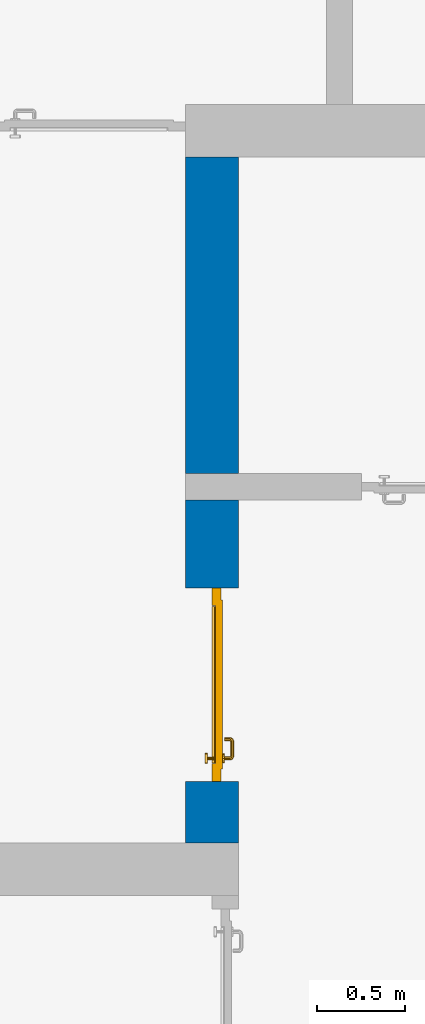
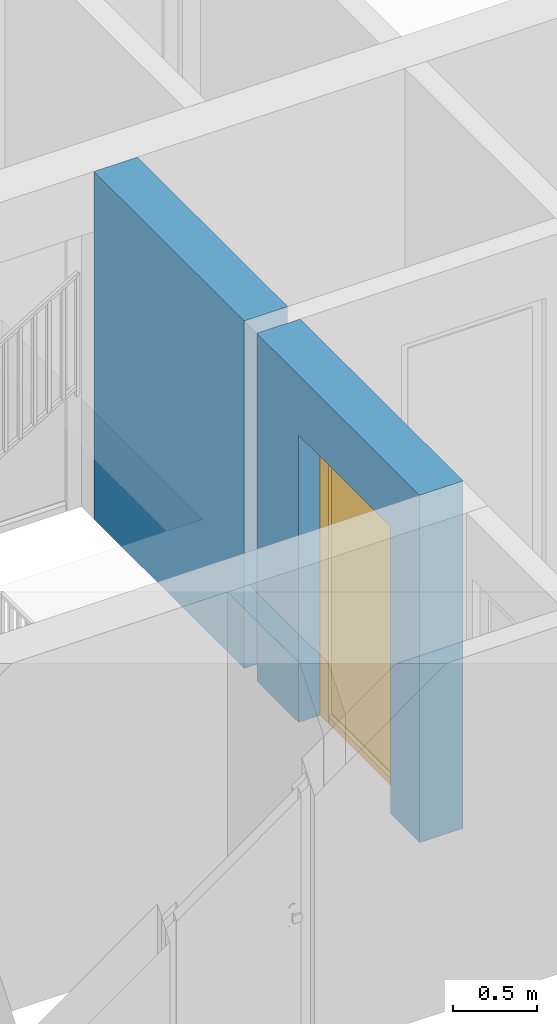
# One storey, part 15 of 54: 1 door, 1 wall, 1 opening.
"""IFC4 building model written with IfcOpenShell, lengths in metres."""

from ifc_helpers import new_model, entity, si_unit, converted_unit, derived_unit, direction, frame, origin_with_axes, place, context, subcontext, project, spatial, polygons, source, transform, mapped, material, type_object, element, fill, save


model = new_model("IFC4")

# Units and contexts
model_context = context("Model", 3, precision=1e-05, world=origin_with_axes(), true_north=direction((0.0, 1.0)))
body_context = subcontext(model_context, "Body", "Model", "MODEL_VIEW")
ifc_project = project(units=[si_unit("LENGTHUNIT", "METRE"), si_unit("AREAUNIT", "SQUARE_METRE"), si_unit("VOLUMEUNIT", "CUBIC_METRE"), converted_unit("PLANEANGLEUNIT", "DEGREE", entity("IfcPlaneAngleMeasure", 0.0174532925199), si_unit("PLANEANGLEUNIT", "RADIAN"), dimensions=[0, 0, 0, 0, 0, 0, 0]), converted_unit("TIMEUNIT", "Year", entity("IfcTimeMeasure", 31556926.0), si_unit("TIMEUNIT", "SECOND"), dimensions=[0, 0, 1, 0, 0, 0, 0]), si_unit("MASSUNIT", "GRAM", prefix="KILO"), si_unit("THERMODYNAMICTEMPERATUREUNIT", "DEGREE_CELSIUS"), si_unit("LUMINOUSINTENSITYUNIT", "LUMEN"), si_unit("ENERGYUNIT", "JOULE", prefix="MEGA"), derived_unit("THERMALCONDUCTANCEUNIT", [(si_unit("POWERUNIT", "WATT"), 1), (si_unit("LENGTHUNIT", "METRE"), -1), (si_unit("THERMODYNAMICTEMPERATUREUNIT", "KELVIN"), -1)]), derived_unit("SPECIFICHEATCAPACITYUNIT", [(si_unit("ENERGYUNIT", "JOULE"), 1), (si_unit("MASSUNIT", "GRAM", prefix="KILO"), -1), (si_unit("THERMODYNAMICTEMPERATUREUNIT", "KELVIN"), -1)]), derived_unit("MASSDENSITYUNIT", [(si_unit("MASSUNIT", "GRAM", prefix="KILO"), 1), (si_unit("VOLUMEUNIT", "CUBIC_METRE"), -1)])], contexts=[model_context])

# Site, building, storey
site_placement = place(None, origin_with_axes())
site = spatial("IfcSite", under=ifc_project, at=site_placement, CompositionType="ELEMENT")
building_placement = place(site_placement, origin_with_axes())
building = spatial("IfcBuilding", under=site, at=building_placement, CompositionType="ELEMENT")
storey_placement = place(building_placement, frame((0.0, 0.0, 6.29), z_axis=(0.0, 0.0, 1.0), x_axis=(1.0, 0.0, 0.0)))
storey = spatial("IfcBuildingStorey", under=building, at=storey_placement, Name="2. Geschoss", CompositionType="ELEMENT", Elevation=6.29)

# Wall, opening, door
ifc_material = material()
wall_type = type_object("IfcWallType", Name="300", PredefinedType="NOTDEFINED")
wall_placement = place(storey_placement, frame((2.8378006196, -2.52881223104, 0.0), z_axis=(0.0, 0.0, 1.0), x_axis=(0.0, 1.0, 0.0)))
wall = element("IfcWall", 1, at=wall_placement, inside=storey, type_object=wall_type, material=ifc_material, Name="Wand-001", PredefinedType="NOTDEFINED", context=body_context, shape_type="Tessellation", body=[
    polygons([(3.9, 0.3, 0.0), (3.9, 0.3, 2.54), (3.9, 0.0, 2.54), (3.9, 0.0, 0.0), (2.1, 0.3, 0.0), (2.1, 0.3, 2.54), (2.1, 0.0, 2.54), (2.1, 0.0, 0.0)], [[[1, 2, 3, 4]], [[5, 6, 2, 1]], [[6, 7, 3, 2]], [[4, 3, 7, 8]], [[5, 1, 4, 8]], [[8, 7, 6, 5]]], closed=True),
    polygons([(0.35, 0.0, 0.0), (0.35, 0.0, 2.1), (1.45, 0.0, 2.1), (1.45, 0.0, 0.0), (1.95, 0.0, 0.0), (1.95, 0.0, 2.54), (0.0, 0.0, 2.54), (0.0, 0.0, 0.0), (0.35, 0.15, 0.0), (0.35, 0.3, 0.0), (0.35, 0.3, 2.1), (1.45, 0.3, 2.1), (1.45, 0.15, 0.0), (1.45, 0.3, 0.0), (1.95, 0.3, 0.0), (1.95, 0.3, 2.54), (0.0, 0.3, 2.54), (0.0, 0.3, 0.0)], [[[1, 2, 3, 4, 5, 6, 7, 8]], [[2, 1, 9, 10, 11]], [[3, 2, 11, 12]], [[13, 4, 3, 12, 14]], [[4, 13, 14, 15, 5]], [[6, 5, 15, 16]], [[6, 16, 17, 7]], [[17, 18, 8, 7]], [[9, 1, 8, 18, 10]], [[15, 14, 12, 11, 10, 18, 17, 16]]], closed=True),
])
opening_placement = place(wall_placement, frame((0.9, 0.0, 0.0), z_axis=(0.0, 0.0, 1.0), x_axis=(1.0, 0.0, 0.0)))
opening = element("IfcOpeningElement", 2, at=opening_placement, cuts=wall, context=body_context, identifier="Reference", shape_type="Tessellation", body=[
    polygons([(-0.55, 0.15, 0.0), (-0.55, 0.15, 2.1), (-0.55, 0.301, 2.1), (-0.55, 0.301, 0.0), (-0.55, -0.001, 0.0), (-0.55, -0.001, 2.1), (0.55, 0.15, 2.1), (0.55, 0.301, 2.1), (0.55, -0.001, 2.1), (0.55, 0.301, 0.0), (0.55, 0.15, 0.0), (0.55, -0.001, 0.0)], [[[1, 2, 3, 4]], [[2, 1, 5, 6]], [[7, 8, 3, 2, 6, 9]], [[8, 10, 4, 3]], [[1, 4, 10, 11, 12, 5]], [[6, 5, 12, 9]], [[7, 11, 10, 8]], [[11, 7, 9, 12]]], closed=True),
])
door_type = type_object("IfcDoorType", Name="Eingang 01 1-Fl 26", OperationType="SINGLE_SWING_LEFT", PredefinedType="DOOR")
shared_shape = source(origin_with_axes(), body_context, "Body", "Tessellation", [
    polygons([(-0.55, -0.05, 0.0), (-0.55, -0.05, 2.1), (-0.55, -0.03, 2.1), (-0.55, -0.03, 0.0), (-0.45, -0.05, 0.0), (-0.45, -0.05, 2.0), (-0.1301, -0.05, 2.0), (-0.0001, -0.05, 2.0), (0.45, -0.05, 2.0), (0.45, -0.05, 0.0), (0.55, -0.05, 0.0), (0.55, -0.05, 2.1), (0.55, -0.03, 2.1), (0.55, -0.03, 0.0), (0.45, -0.03, 0.0), (0.45, -0.03, 2.0), (-0.0001, -0.03, 2.0), (-0.1301, -0.03, 2.0), (-0.45, -0.03, 2.0), (-0.45, -0.03, 0.0)], [[[1, 2, 3, 4]], [[1, 5, 6, 7, 8, 9, 10, 11, 12, 2]], [[2, 12, 13, 3]], [[4, 3, 13, 14, 15, 16, 17, 18, 19, 20]], [[5, 1, 4, 20]], [[6, 5, 20, 19]], [[7, 6, 19, 18]], [[8, 7, 18, 17]], [[9, 8, 17, 16]], [[10, 9, 16, 15]], [[11, 10, 15, 14]], [[12, 11, 14, 13]]], closed=True),
    polygons([(-0.55, -0.03, 0.0), (-0.55, -0.03, 2.1), (-0.55, 0.0, 2.1), (-0.55, 0.0, 0.0), (-0.48, -0.03, 0.0), (-0.48, -0.03, 2.03), (-0.1001, -0.03, 2.03), (-0.0301, -0.03, 2.03), (0.48, -0.03, 2.03), (0.48, -0.03, 0.0), (0.55, -0.03, 0.0), (0.55, -0.03, 2.1), (0.55, 0.0, 2.1), (0.55, 0.0, 0.0), (0.48, 0.0, 0.0), (0.48, 0.0, 2.03), (-0.0301, 0.0, 2.03), (-0.1001, 0.0, 2.03), (-0.48, 0.0, 2.03), (-0.48, 0.0, 0.0)], [[[1, 2, 3, 4]], [[1, 5, 6, 7, 8, 9, 10, 11, 12, 2]], [[2, 12, 13, 3]], [[4, 3, 13, 14, 15, 16, 17, 18, 19, 20]], [[5, 1, 4, 20]], [[6, 5, 20, 19]], [[7, 6, 19, 18]], [[8, 7, 18, 17]], [[9, 8, 17, 16]], [[10, 9, 16, 15]], [[11, 10, 15, 14]], [[12, 11, 14, 13]]], closed=True),
    polygons([(-0.48, 0.01, 0.0), (-0.48, 0.01, 2.03), (0.48, 0.01, 2.03), (0.48, 0.01, 0.0), (-0.48, -0.03, 0.0), (-0.48, -0.03, 2.03), (0.48, -0.03, 2.03), (0.48, -0.03, 0.0)], [[[1, 2, 3, 4]], [[1, 5, 6, 2]], [[2, 6, 7, 3]], [[3, 7, 8, 4]], [[4, 8, 5, 1]], [[8, 7, 6, 5]]], closed=True),
    polygons([(-0.445, -0.05, 0.0), (0.445, -0.05, 0.0), (0.445, -0.05, 0.05), (-0.445, -0.05, 0.05), (-0.445, -0.03, 0.0), (0.445, -0.03, 0.0), (0.445, -0.03, 0.07), (0.445, -0.035, 0.07), (-0.445, -0.035, 0.07), (-0.445, -0.03, 0.07)], [[[1, 2, 3, 4]], [[5, 6, 2, 1]], [[2, 6, 7, 8, 3]], [[4, 3, 8, 9]], [[1, 4, 9, 10, 5]], [[10, 7, 6, 5]], [[9, 8, 7, 10]]], closed=True),
    polygons([(0.4335, 0.02, 1.0733826859), (0.42, 0.02, 1.077), (0.42, 0.0199, 1.077), (0.4335, 0.0199, 1.0733826859), (0.443382685902, 0.02, 1.0635), (0.447, 0.02, 1.05), (0.443382685902, 0.02, 1.0365), (0.4335, 0.02, 1.0266173141), (0.42, 0.02, 1.023), (0.4065, 0.02, 1.0266173141), (0.396617314098, 0.02, 1.0365), (0.393, 0.02, 1.05), (0.396617314098, 0.02, 1.0635), (0.4065, 0.02, 1.0733826859), (0.4065, 0.0199, 1.0733826859), (0.42, 0.0101, 1.077), (0.4335, 0.0101, 1.0733826859), (0.443382685902, 0.0199, 1.0635), (0.447, 0.0199, 1.05), (0.443382685902, 0.0199, 1.0365), (0.4335, 0.0199, 1.0266173141), (0.42, 0.0199, 1.023), (0.4065, 0.0199, 1.0266173141), (0.396617314098, 0.0199, 1.0365), (0.393, 0.0199, 1.05), (0.396617314098, 0.0199, 1.0635), (0.4065, 0.0101, 1.0733826859), (0.42, 0.01, 1.077), (0.4335, 0.01, 1.0733826859), (0.443382685902, 0.0101, 1.0635), (0.447, 0.0101, 1.05), (0.443382685902, 0.0101, 1.0365), (0.4335, 0.0101, 1.0266173141), (0.42, 0.0101, 1.023), (0.4065, 0.0101, 1.0266173141), (0.396617314098, 0.0101, 1.0365), (0.393, 0.0101, 1.05), (0.396617314098, 0.0101, 1.0635), (0.4065, 0.01, 1.0733826859), (0.396617314098, 0.01, 1.0635), (0.393, 0.01, 1.05), (0.396617314098, 0.01, 1.0365), (0.4065, 0.01, 1.0266173141), (0.42, 0.01, 1.023), (0.4335, 0.01, 1.0266173141), (0.443382685902, 0.01, 1.0365), (0.447, 0.01, 1.05), (0.443382685902, 0.01, 1.0635)], [[[1, 2, 3, 4]], [[2, 1, 5, 6, 7, 8, 9, 10, 11, 12, 13, 14]], [[2, 14, 15, 3]], [[4, 3, 16, 17]], [[5, 1, 4, 18]], [[6, 5, 18, 19]], [[7, 6, 19, 20]], [[8, 7, 20, 21]], [[9, 8, 21, 22]], [[10, 9, 22, 23]], [[11, 10, 23, 24]], [[12, 11, 24, 25]], [[13, 12, 25, 26]], [[14, 13, 26, 15]], [[3, 15, 27, 16]], [[17, 16, 28, 29]], [[18, 4, 17, 30]], [[19, 18, 30, 31]], [[20, 19, 31, 32]], [[21, 20, 32, 33]], [[22, 21, 33, 34]], [[23, 22, 34, 35]], [[24, 23, 35, 36]], [[25, 24, 36, 37]], [[26, 25, 37, 38]], [[15, 26, 38, 27]], [[16, 27, 39, 28]], [[28, 39, 40, 41, 42, 43, 44, 45, 46, 47, 48, 29]], [[30, 17, 29, 48]], [[31, 30, 48, 47]], [[32, 31, 47, 46]], [[33, 32, 46, 45]], [[34, 33, 45, 44]], [[35, 34, 44, 43]], [[36, 35, 43, 42]], [[37, 36, 42, 41]], [[38, 37, 41, 40]], [[27, 38, 40, 39]]], closed=True),
    polygons([(0.412532169224, 0.019, 0.959692280177), (0.413279754556, 0.019, 0.961639806549), (0.40705, 0.019, 0.972430057958), (0.397569942042, 0.019, 0.96295), (0.415, 0.019, 0.952886751346), (0.415, 0.019, 0.9544), (0.412532169224, 0.02, 0.959692280177), (0.413279754556, 0.02, 0.961639806549), (0.414624817685, 0.02, 0.965143815798), (0.414624817685, 0.019, 0.965143815798), (0.42, 0.019, 0.967425445323), (0.42, 0.019, 0.9759), (0.407, 0.019, 0.972516660498), (0.397483339502, 0.019, 0.963), (0.415, 0.019, 0.95), (0.3941, 0.019, 0.95), (0.415, 0.019, 0.947113248654), (0.415, 0.019, 0.941339745962), (0.415, 0.019, 0.9375), (0.415, 0.02, 0.9375), (0.415, 0.02, 0.941339745962), (0.415, 0.02, 0.947113248654), (0.415, 0.02, 0.95), (0.415, 0.02, 0.952886751346), (0.415, 0.02, 0.9544), (0.396703916638, 0.02, 0.96345), (0.40655, 0.02, 0.973296083362), (0.42, 0.02, 0.9769), (0.42, 0.02, 0.967425445323), (0.425375182315, 0.019, 0.965143815798), (0.426720245444, 0.019, 0.961639806549), (0.43295, 0.019, 0.972430057958), (0.42, 0.019, 0.976), (0.407, 0.0189, 0.972516660498), (0.397483339502, 0.0189, 0.963), (0.394, 0.019, 0.95), (0.397569942042, 0.019, 0.93705), (0.40705, 0.019, 0.927569942042), (0.42, 0.019, 0.9241), (0.42, 0.019, 0.9325), (0.416464466094, 0.019, 0.933964466094), (0.416464466094, 0.02, 0.933964466094), (0.42, 0.02, 0.9231), (0.40655, 0.02, 0.926703916638), (0.42, 0.02, 0.9325), (0.396703916638, 0.02, 0.93655), (0.3931, 0.02, 0.95), (0.396617314098, 0.02, 0.9635), (0.4065, 0.02, 0.973382685902), (0.42, 0.02, 0.977), (0.425375182315, 0.02, 0.965143815798), (0.43345, 0.02, 0.973296083362), (0.426720245444, 0.02, 0.961639806549), (0.427467830776, 0.02, 0.959692280177), (0.427467830776, 0.019, 0.959692280177), (0.425, 0.019, 0.9544), (0.425, 0.019, 0.952886751346), (0.442430057958, 0.019, 0.96295), (0.433, 0.019, 0.972516660498), (0.42, 0.0189, 0.976), (0.407, 0.0101, 0.972516660498), (0.397483339502, 0.0101, 0.963), (0.394, 0.0189, 0.95), (0.397483339502, 0.019, 0.937), (0.407, 0.019, 0.927483339502), (0.42, 0.019, 0.924), (0.43295, 0.019, 0.927569942042), (0.425, 0.019, 0.941339745962), (0.425, 0.019, 0.9375), (0.423535533906, 0.019, 0.933964466094), (0.42, 0.02, 0.923), (0.4065, 0.02, 0.926617314098), (0.43345, 0.02, 0.926703916638), (0.423535533906, 0.02, 0.933964466094), (0.425, 0.02, 0.9375), (0.425, 0.02, 0.941339745962), (0.396617314098, 0.02, 0.9365), (0.393, 0.02, 0.95), (0.396617314098, 0.0199, 0.9635), (0.4065, 0.0199, 0.973382685902), (0.42, 0.0199, 0.977), (0.4335, 0.02, 0.973382685902), (0.443296083362, 0.02, 0.96345), (0.425, 0.02, 0.952886751346), (0.425, 0.02, 0.9544), (0.425, 0.02, 0.95), (0.425, 0.02, 0.947113248654), (0.425, 0.019, 0.947113248654), (0.425, 0.019, 0.95), (0.4459, 0.019, 0.95), (0.442516660498, 0.019, 0.963), (0.433, 0.0189, 0.972516660498), (0.42, 0.0101, 0.976), (0.407, 0.01, 0.972516660498), (0.397483339502, 0.01, 0.963), (0.394, 0.0101, 0.95), (0.397483339502, 0.0189, 0.937), (0.407, 0.0189, 0.927483339502), (0.42, 0.0189, 0.924), (0.433, 0.019, 0.927483339502), (0.442430057958, 0.019, 0.93705), (0.42, 0.0199, 0.923), (0.4065, 0.0199, 0.926617314098), (0.4335, 0.02, 0.926617314098), (0.443296083362, 0.02, 0.93655), (0.396617314098, 0.0199, 0.9365), (0.393, 0.0199, 0.95), (0.396617314098, 0.0101, 0.9635), (0.4065, 0.0101, 0.973382685902), (0.42, 0.0101, 0.977), (0.4335, 0.0199, 0.973382685902), (0.443382685902, 0.02, 0.9635), (0.4469, 0.02, 0.95), (0.446, 0.019, 0.95), (0.442516660498, 0.0189, 0.963), (0.433, 0.0101, 0.972516660498), (0.42, 0.01, 0.976), (0.40695, 0.01, 0.972603263039), (0.397396736961, 0.01, 0.96305), (0.394, 0.01, 0.95), (0.397483339502, 0.0101, 0.937), (0.407, 0.0101, 0.927483339502), (0.42, 0.0101, 0.924), (0.433, 0.0189, 0.927483339502), (0.442516660498, 0.019, 0.937), (0.42, 0.0101, 0.923), (0.4065, 0.0101, 0.926617314098), (0.4335, 0.0199, 0.926617314098), (0.443382685902, 0.02, 0.9365), (0.396617314098, 0.0101, 0.9365), (0.393, 0.0101, 0.95), (0.396617314098, 0.01, 0.9635), (0.4065, 0.01, 0.973382685902), (0.42, 0.01, 0.977), (0.4335, 0.0101, 0.973382685902), (0.443382685902, 0.0199, 0.9635), (0.447, 0.02, 0.95), (0.446, 0.0189, 0.95), (0.442516660498, 0.0101, 0.963), (0.433, 0.01, 0.972516660498), (0.42, 0.01, 0.9761), (0.40655, 0.01, 0.973296083362), (0.396703916638, 0.01, 0.96345), (0.3939, 0.01, 0.95), (0.397483339502, 0.01, 0.937), (0.407, 0.01, 0.927483339502), (0.42, 0.01, 0.924), (0.433, 0.0101, 0.927483339502), (0.442516660498, 0.0189, 0.937), (0.42, 0.01, 0.923), (0.4065, 0.01, 0.926617314098), (0.4335, 0.0101, 0.926617314098), (0.443382685902, 0.0199, 0.9365), (0.396617314098, 0.01, 0.9365), (0.393, 0.01, 0.95), (0.42, 0.01, 0.9769), (0.4335, 0.01, 0.973382685902), (0.443382685902, 0.0101, 0.9635), (0.447, 0.0199, 0.95), (0.446, 0.0101, 0.95), (0.442516660498, 0.01, 0.963), (0.43305, 0.01, 0.972603263039), (0.3931, 0.01, 0.95), (0.397396736961, 0.01, 0.93695), (0.40695, 0.01, 0.927396736961), (0.42, 0.01, 0.9239), (0.433, 0.01, 0.927483339502), (0.442516660498, 0.0101, 0.937), (0.42, 0.01, 0.9231), (0.40655, 0.01, 0.926703916638), (0.4335, 0.01, 0.926617314098), (0.443382685902, 0.0101, 0.9365), (0.396703916638, 0.01, 0.93655), (0.43345, 0.01, 0.973296083362), (0.443382685902, 0.01, 0.9635), (0.447, 0.0101, 0.95), (0.446, 0.01, 0.95), (0.442603263039, 0.01, 0.96305), (0.43305, 0.01, 0.927396736961), (0.442516660498, 0.01, 0.937), (0.43345, 0.01, 0.926703916638), (0.443382685902, 0.01, 0.9365), (0.443296083362, 0.01, 0.96345), (0.447, 0.01, 0.95), (0.4461, 0.01, 0.95), (0.442603263039, 0.01, 0.93695), (0.443296083362, 0.01, 0.93655), (0.4469, 0.01, 0.95)], [[[1, 2, 3, 4, 5, 6]], [[1, 7, 8, 9, 10, 2]], [[10, 11, 12, 3, 2]], [[4, 3, 13, 14]], [[15, 5, 4, 16]], [[6, 5, 15, 17, 18, 19, 20, 21, 22, 23, 24, 25]], [[6, 25, 7, 1]], [[7, 25, 24, 26, 27, 8]], [[9, 8, 27, 28, 29]], [[10, 9, 29, 11]], [[30, 31, 32, 12, 11]], [[3, 12, 33, 13]], [[14, 13, 34, 35]], [[16, 4, 14, 36]], [[17, 15, 16, 37]], [[18, 17, 37, 38]], [[38, 39, 40, 41, 19, 18]], [[19, 41, 42, 20]], [[43, 44, 21, 20, 42, 45]], [[22, 21, 44, 46]], [[23, 22, 46, 47]], [[24, 23, 47, 26]], [[48, 49, 27, 26]], [[49, 50, 28, 27]], [[51, 29, 28, 52, 53]], [[11, 29, 51, 30]], [[30, 51, 53, 54, 55, 31]], [[55, 56, 57, 58, 32, 31]], [[12, 32, 59, 33]], [[13, 33, 60, 34]], [[35, 34, 61, 62]], [[36, 14, 35, 63]], [[37, 16, 36, 64]], [[38, 37, 64, 65]], [[39, 38, 65, 66]], [[39, 67, 68, 69, 70, 40]], [[41, 40, 45, 42]], [[71, 72, 44, 43]], [[73, 43, 45, 74, 75, 76]], [[72, 77, 46, 44]], [[77, 78, 47, 46]], [[78, 48, 26, 47]], [[79, 80, 49, 48]], [[80, 81, 50, 49]], [[50, 82, 52, 28]], [[54, 53, 52, 83, 84, 85]], [[55, 54, 85, 56]], [[85, 84, 86, 87, 76, 75, 69, 68, 88, 89, 57, 56]], [[57, 89, 90, 58]], [[32, 58, 91, 59]], [[33, 59, 92, 60]], [[34, 60, 93, 61]], [[62, 61, 94, 95]], [[63, 35, 62, 96]], [[64, 36, 63, 97]], [[65, 64, 97, 98]], [[66, 65, 98, 99]], [[67, 39, 66, 100]], [[88, 68, 67, 101]], [[70, 69, 75, 74]], [[40, 70, 74, 45]], [[102, 103, 72, 71]], [[104, 71, 43, 73]], [[76, 87, 105, 73]], [[103, 106, 77, 72]], [[106, 107, 78, 77]], [[107, 79, 48, 78]], [[108, 109, 80, 79]], [[109, 110, 81, 80]], [[81, 111, 82, 50]], [[82, 112, 83, 52]], [[86, 84, 83, 113]], [[87, 86, 113, 105]], [[89, 88, 101, 90]], [[58, 90, 114, 91]], [[59, 91, 115, 92]], [[60, 92, 116, 93]], [[61, 93, 117, 94]], [[95, 94, 118, 119]], [[96, 62, 95, 120]], [[97, 63, 96, 121]], [[98, 97, 121, 122]], [[99, 98, 122, 123]], [[100, 66, 99, 124]], [[101, 67, 100, 125]], [[126, 127, 103, 102]], [[128, 102, 71, 104]], [[129, 104, 73, 105]], [[127, 130, 106, 103]], [[130, 131, 107, 106]], [[131, 108, 79, 107]], [[132, 133, 109, 108]], [[133, 134, 110, 109]], [[110, 135, 111, 81]], [[111, 136, 112, 82]], [[112, 137, 113, 83]], [[137, 129, 105, 113]], [[90, 101, 125, 114]], [[91, 114, 138, 115]], [[92, 115, 139, 116]], [[93, 116, 140, 117]], [[94, 117, 141, 118]], [[119, 118, 142, 143]], [[120, 95, 119, 144]], [[121, 96, 120, 145]], [[122, 121, 145, 146]], [[123, 122, 146, 147]], [[124, 99, 123, 148]], [[125, 100, 124, 149]], [[150, 151, 127, 126]], [[152, 126, 102, 128]], [[153, 128, 104, 129]], [[151, 154, 130, 127]], [[154, 155, 131, 130]], [[155, 132, 108, 131]], [[143, 142, 133, 132]], [[142, 156, 134, 133]], [[134, 157, 135, 110]], [[135, 158, 136, 111]], [[136, 159, 137, 112]], [[159, 153, 129, 137]], [[114, 125, 149, 138]], [[115, 138, 160, 139]], [[116, 139, 161, 140]], [[117, 140, 162, 141]], [[118, 141, 156, 142]], [[144, 119, 143, 163]], [[145, 120, 144, 164]], [[146, 145, 164, 165]], [[147, 146, 165, 166]], [[148, 123, 147, 167]], [[149, 124, 148, 168]], [[169, 170, 151, 150]], [[171, 150, 126, 152]], [[172, 152, 128, 153]], [[170, 173, 154, 151]], [[173, 163, 155, 154]], [[163, 143, 132, 155]], [[156, 174, 157, 134]], [[157, 175, 158, 135]], [[158, 176, 159, 136]], [[176, 172, 153, 159]], [[138, 149, 168, 160]], [[139, 160, 177, 161]], [[140, 161, 178, 162]], [[141, 162, 174, 156]], [[164, 144, 163, 173]], [[165, 164, 173, 170]], [[166, 165, 170, 169]], [[167, 147, 166, 179]], [[168, 148, 167, 180]], [[181, 169, 150, 171]], [[182, 171, 152, 172]], [[174, 183, 175, 157]], [[175, 184, 176, 158]], [[184, 182, 172, 176]], [[160, 168, 180, 177]], [[161, 177, 185, 178]], [[162, 178, 183, 174]], [[179, 166, 169, 181]], [[180, 167, 179, 186]], [[187, 181, 171, 182]], [[183, 188, 184, 175]], [[188, 187, 182, 184]], [[177, 180, 186, 185]], [[178, 185, 188, 183]], [[186, 179, 181, 187]], [[185, 186, 187, 188]]], closed=True),
    polygons([(0.43, 0.02, 1.05), (0.427071067812, 0.02, 1.04292893219), (0.427071067812, 0.050696439392, 1.04292893219), (0.43, 0.0509849140336, 1.05), (0.42, 0.02, 1.04), (0.42, 0.05, 1.04), (0.425518993221, 0.0584992452783, 1.04292893219), (0.428277987014, 0.0596420579258, 1.05), (0.427071067812, 0.02, 1.05707106781), (0.427071067812, 0.050696439392, 1.05707106781), (0.412928932188, 0.02, 1.04292893219), (0.412928932188, 0.049303560608, 1.04292893219), (0.418858192988, 0.0557402514855, 1.04), (0.420704557509, 0.0657045575088, 1.04292893219), (0.422816199938, 0.0678161999379, 1.05), (0.425518993221, 0.0584992452783, 1.05707106781), (0.42, 0.02, 1.06), (0.42, 0.05, 1.06), (0.41, 0.02, 1.05), (0.41, 0.0490150859664, 1.05), (0.412197392755, 0.0529812576926, 1.04292893219), (0.415606601718, 0.0606066017178, 1.04), (0.413499245278, 0.0705189932208, 1.04292893219), (0.414642057926, 0.0732779870137, 1.05), (0.420704557509, 0.0657045575088, 1.05707106781), (0.418858192988, 0.0557402514855, 1.06), (0.412928932188, 0.02, 1.05707106781), (0.412928932188, 0.049303560608, 1.05707106781), (0.409438398962, 0.0518384450452, 1.05), (0.410508645927, 0.0555086459268, 1.04292893219), (0.410740251485, 0.0638581929877, 1.04), (0.405696439392, 0.0720710678119, 1.04292893219), (0.405984914034, 0.075, 1.05), (0.413499245278, 0.0705189932208, 1.05707106781), (0.415606601718, 0.0606066017178, 1.06), (0.412197392755, 0.0529812576926, 1.05707106781), (0.408397003498, 0.0533970034977, 1.05), (0.407981257693, 0.0571973927545, 1.04292893219), (0.405, 0.065, 1.04), (0.324303560608, 0.0720710678119, 1.04292893219), (0.324015085966, 0.075, 1.05), (0.405696439392, 0.0720710678119, 1.05707106781), (0.410740251485, 0.0638581929877, 1.06), (0.410508645927, 0.0555086459268, 1.05707106781), (0.406838445045, 0.0544383989617, 1.05), (0.404303560608, 0.0579289321881, 1.04292893219), (0.325, 0.065, 1.04), (0.316500754722, 0.0705189932208, 1.04292893219), (0.315357942074, 0.0732779870137, 1.05), (0.324303560608, 0.0720710678119, 1.05707106781), (0.405, 0.065, 1.06), (0.407981257693, 0.0571973927545, 1.05707106781), (0.404015085966, 0.055, 1.05), (0.325696439392, 0.0579289321881, 1.04292893219), (0.319259748515, 0.0638581929877, 1.04), (0.309295442491, 0.0657045575088, 1.04292893219), (0.307183800062, 0.0678161999379, 1.05), (0.316500754722, 0.0705189932208, 1.05707106781), (0.325, 0.065, 1.06), (0.404303560608, 0.0579289321881, 1.05707106781), (0.325984914034, 0.055, 1.05), (0.322018742307, 0.0571973927545, 1.04292893219), (0.314393398282, 0.0606066017178, 1.04), (0.304481006779, 0.0584992452783, 1.04292893219), (0.301722012986, 0.0596420579258, 1.05), (0.309295442491, 0.0657045575088, 1.05707106781), (0.319259748515, 0.0638581929877, 1.06), (0.325696439392, 0.0579289321881, 1.05707106781), (0.323161554955, 0.0544383989617, 1.05), (0.319491354073, 0.0555086459268, 1.04292893219), (0.311141807012, 0.0557402514855, 1.04), (0.302928932188, 0.050696439392, 1.04292893219), (0.3, 0.0509849140336, 1.05), (0.304481006779, 0.0584992452783, 1.05707106781), (0.314393398282, 0.0606066017178, 1.06), (0.322018742307, 0.0571973927545, 1.05707106781), (0.321602996502, 0.0533970034977, 1.05), (0.317802607245, 0.0529812576926, 1.04292893219), (0.31, 0.05, 1.04), (0.302928932188, 0.02, 1.04292893219), (0.3, 0.02, 1.05), (0.302928932188, 0.050696439392, 1.05707106781), (0.311141807012, 0.0557402514855, 1.06), (0.319491354073, 0.0555086459268, 1.05707106781), (0.320561601038, 0.0518384450452, 1.05), (0.317071067812, 0.049303560608, 1.04292893219), (0.31, 0.02, 1.04), (0.317071067812, 0.02, 1.04292893219), (0.32, 0.02, 1.05), (0.317071067812, 0.02, 1.05707106781), (0.31, 0.02, 1.06), (0.302928932188, 0.02, 1.05707106781), (0.31, 0.05, 1.06), (0.317802607245, 0.0529812576926, 1.05707106781), (0.32, 0.0490150859664, 1.05), (0.317071067812, 0.049303560608, 1.05707106781)], [[[1, 2, 3, 4]], [[2, 5, 6, 3]], [[4, 3, 7, 8]], [[9, 1, 4, 10]], [[5, 11, 12, 6]], [[3, 6, 13, 7]], [[8, 7, 14, 15]], [[10, 4, 8, 16]], [[17, 9, 10, 18]], [[11, 19, 20, 12]], [[6, 12, 21, 13]], [[7, 13, 22, 14]], [[15, 14, 23, 24]], [[16, 8, 15, 25]], [[18, 10, 16, 26]], [[27, 17, 18, 28]], [[19, 27, 28, 20]], [[12, 20, 29, 21]], [[13, 21, 30, 22]], [[14, 22, 31, 23]], [[24, 23, 32, 33]], [[25, 15, 24, 34]], [[26, 16, 25, 35]], [[28, 18, 26, 36]], [[20, 28, 36, 29]], [[21, 29, 37, 30]], [[22, 30, 38, 31]], [[23, 31, 39, 32]], [[33, 32, 40, 41]], [[34, 24, 33, 42]], [[35, 25, 34, 43]], [[36, 26, 35, 44]], [[29, 36, 44, 37]], [[30, 37, 45, 38]], [[31, 38, 46, 39]], [[32, 39, 47, 40]], [[41, 40, 48, 49]], [[42, 33, 41, 50]], [[43, 34, 42, 51]], [[44, 35, 43, 52]], [[37, 44, 52, 45]], [[38, 45, 53, 46]], [[39, 46, 54, 47]], [[40, 47, 55, 48]], [[49, 48, 56, 57]], [[50, 41, 49, 58]], [[51, 42, 50, 59]], [[52, 43, 51, 60]], [[45, 52, 60, 53]], [[46, 53, 61, 54]], [[47, 54, 62, 55]], [[48, 55, 63, 56]], [[57, 56, 64, 65]], [[58, 49, 57, 66]], [[59, 50, 58, 67]], [[60, 51, 59, 68]], [[53, 60, 68, 61]], [[54, 61, 69, 62]], [[55, 62, 70, 63]], [[56, 63, 71, 64]], [[65, 64, 72, 73]], [[66, 57, 65, 74]], [[67, 58, 66, 75]], [[68, 59, 67, 76]], [[61, 68, 76, 69]], [[62, 69, 77, 70]], [[63, 70, 78, 71]], [[64, 71, 79, 72]], [[73, 72, 80, 81]], [[74, 65, 73, 82]], [[75, 66, 74, 83]], [[76, 67, 75, 84]], [[69, 76, 84, 77]], [[70, 77, 85, 78]], [[71, 78, 86, 79]], [[72, 79, 87, 80]], [[81, 80, 87, 88, 89, 90, 91, 92]], [[82, 73, 81, 92]], [[83, 74, 82, 93]], [[84, 75, 83, 94]], [[77, 84, 94, 85]], [[78, 85, 95, 86]], [[79, 86, 88, 87]], [[86, 95, 89, 88]], [[95, 96, 90, 89]], [[96, 93, 91, 90]], [[93, 82, 92, 91]], [[94, 83, 93, 96]], [[85, 94, 96, 95]]], closed=False),
    polygons([(0.414696699141, -0.035, 1.04469669914), (0.4125, -0.035, 1.05), (0.414696699141, -0.035, 1.05530330086), (0.42, -0.035, 1.0575), (0.425303300859, -0.035, 1.05530330086), (0.4275, -0.035, 1.05), (0.425303300859, -0.035, 1.04469669914), (0.42, -0.035, 1.0425), (0.414696699141, -0.075, 1.04469669914), (0.4125, -0.075, 1.05), (0.414696699141, -0.075, 1.05530330086), (0.42, -0.075, 1.0575), (0.425303300859, -0.075, 1.05530330086), (0.4275, -0.075, 1.05), (0.425303300859, -0.075, 1.04469669914), (0.42, -0.075, 1.0425)], [[[1, 2, 3, 4, 5, 6, 7, 8]], [[1, 9, 10, 2]], [[2, 10, 11, 3]], [[3, 11, 12, 4]], [[4, 12, 13, 5]], [[5, 13, 14, 6]], [[6, 14, 15, 7]], [[7, 15, 16, 8]], [[8, 16, 9, 1]], [[9, 16, 15, 14, 13, 12, 11, 10]]], closed=True),
    polygons([(0.445, -0.03, 0.975), (0.445, -0.035, 0.975), (0.443096988313, -0.035, 0.965432914191), (0.443096988313, -0.03, 0.965432914191), (0.445, -0.03, 1.1), (0.445, -0.035, 1.1), (0.443096988313, -0.035, 1.10956708581), (0.43767766953, -0.035, 1.11767766953), (0.429567085809, -0.035, 1.12309698831), (0.42, -0.035, 1.125), (0.410432914191, -0.035, 1.12309698831), (0.40232233047, -0.035, 1.11767766953), (0.396903011687, -0.035, 1.10956708581), (0.395, -0.035, 1.1), (0.395, -0.035, 0.975), (0.396903011687, -0.035, 0.965432914191), (0.40232233047, -0.035, 0.95732233047), (0.410432914191, -0.035, 0.951903011687), (0.42, -0.035, 0.95), (0.429567085809, -0.035, 0.951903011687), (0.43767766953, -0.035, 0.95732233047), (0.43767766953, -0.03, 0.95732233047), (0.429567085809, -0.03, 0.951903011687), (0.42, -0.03, 0.95), (0.410432914191, -0.03, 0.951903011687), (0.40232233047, -0.03, 0.95732233047), (0.396903011687, -0.03, 0.965432914191), (0.395, -0.03, 0.975), (0.395, -0.03, 1.1), (0.396903011687, -0.03, 1.10956708581), (0.40232233047, -0.03, 1.11767766953), (0.410432914191, -0.03, 1.12309698831), (0.42, -0.03, 1.125), (0.429567085809, -0.03, 1.12309698831), (0.43767766953, -0.03, 1.11767766953), (0.443096988313, -0.03, 1.10956708581)], [[[1, 2, 3, 4]], [[5, 6, 2, 1]], [[2, 6, 7, 8, 9, 10, 11, 12, 13, 14, 15, 16, 17, 18, 19, 20, 21, 3]], [[4, 3, 21, 22]], [[1, 4, 22, 23, 24, 25, 26, 27, 28, 29, 30, 31, 32, 33, 34, 35, 36, 5]], [[36, 7, 6, 5]], [[35, 8, 7, 36]], [[34, 9, 8, 35]], [[33, 10, 9, 34]], [[32, 11, 10, 33]], [[31, 12, 11, 32]], [[30, 13, 12, 31]], [[29, 14, 13, 30]], [[28, 15, 14, 29]], [[27, 16, 15, 28]], [[26, 17, 16, 27]], [[25, 18, 17, 26]], [[24, 19, 18, 25]], [[23, 20, 19, 24]], [[22, 21, 20, 23]]], closed=True),
    polygons([(0.44, -0.075, 1.08), (0.44, -0.09, 1.08), (0.445, -0.09, 1.07866025404), (0.445, -0.075, 1.07866025404), (0.4, -0.075, 1.08), (0.4, -0.09, 1.08), (0.395, -0.09, 1.07866025404), (0.391339745962, -0.09, 1.075), (0.39, -0.09, 1.07), (0.39, -0.09, 1.03), (0.391339745962, -0.09, 1.025), (0.395, -0.09, 1.02133974596), (0.4, -0.09, 1.02), (0.44, -0.09, 1.02), (0.445, -0.09, 1.02133974596), (0.448660254038, -0.09, 1.025), (0.45, -0.09, 1.03), (0.45, -0.09, 1.07), (0.448660254038, -0.09, 1.075), (0.448660254038, -0.075, 1.075), (0.45, -0.075, 1.07), (0.45, -0.075, 1.03), (0.448660254038, -0.075, 1.025), (0.445, -0.075, 1.02133974596), (0.44, -0.075, 1.02), (0.4, -0.075, 1.02), (0.395, -0.075, 1.02133974596), (0.391339745962, -0.075, 1.025), (0.39, -0.075, 1.03), (0.39, -0.075, 1.07), (0.391339745962, -0.075, 1.075), (0.395, -0.075, 1.07866025404)], [[[1, 2, 3, 4]], [[5, 6, 2, 1]], [[2, 6, 7, 8, 9, 10, 11, 12, 13, 14, 15, 16, 17, 18, 19, 3]], [[4, 3, 19, 20]], [[1, 4, 20, 21, 22, 23, 24, 25, 26, 27, 28, 29, 30, 31, 32, 5]], [[32, 7, 6, 5]], [[31, 8, 7, 32]], [[30, 9, 8, 31]], [[29, 10, 9, 30]], [[28, 11, 10, 29]], [[27, 12, 11, 28]], [[26, 13, 12, 27]], [[25, 14, 13, 26]], [[24, 15, 14, 25]], [[23, 16, 15, 24]], [[22, 17, 16, 23]], [[21, 18, 17, 22]], [[20, 19, 18, 21]]], closed=True),
])
door_placement = place(opening_placement, frame((0.45, 0.0, 0.0), z_axis=(0.0, 0.0, 1.0), x_axis=(-1.0, 0.0, 0.0)))
door = element("IfcDoor", 3, at=door_placement, inside=storey, type_object=door_type, OverallHeight=2.1, OverallWidth=1.1, PredefinedType="DOOR", context=body_context, shape_type="MappedRepresentation", body=[
    mapped(shared_shape, transform((0.45, -0.1, 0.0))),
])
fill(opening, door)

save(model, "model.ifc")
